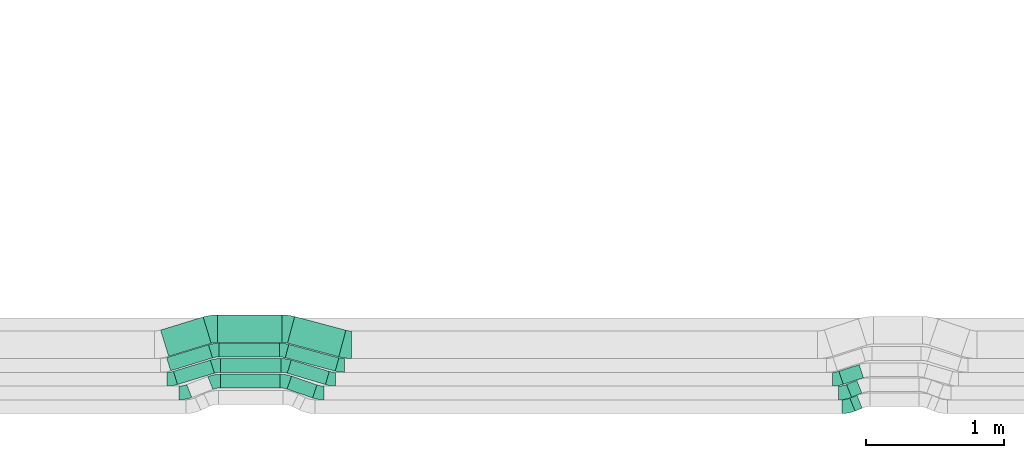
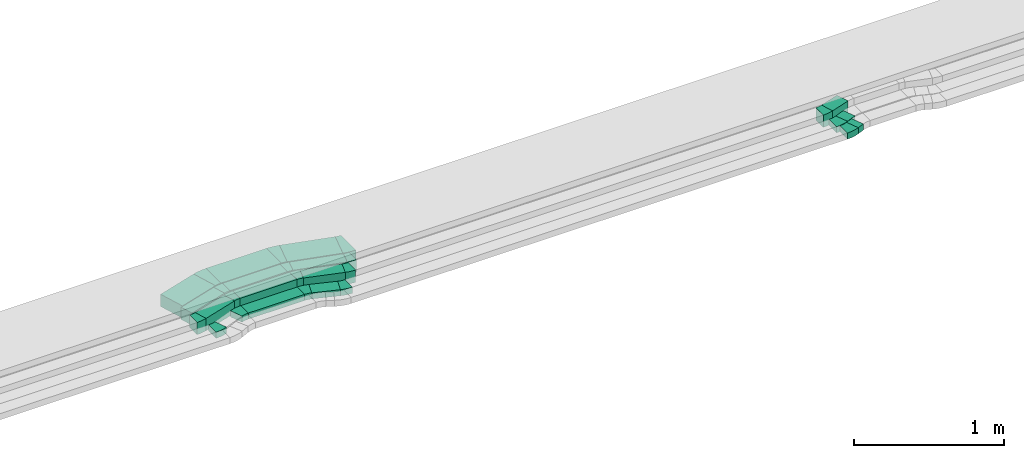
# One storey, part 19 of 38: 17 flow fittings, 14 flow segments.
"""IFC2X3 building model written with IfcOpenShell, lengths in millimetres."""

from ifc_helpers import new_model, entity, si_unit, converted_unit, derived_unit, direction, frame, frame_2d, origin, origin_2d_with_axis, place, context, subcontext, project, spatial, polyline, circle_curve, parameter, trimmed, segment, composite_curve, rectangle, outline, extrude, source, transform, mapped, material, type_object, type_shapes, element, save


model = new_model("IFC2X3")

# Units and contexts
model_context = context("Model", 3, precision=0.01, world=origin(), true_north=direction((6.12303176911189e-17, 1.0)))
body_context = subcontext(model_context, "Body", "Model", "MODEL_VIEW")
ifc_project = project(units=[si_unit("LENGTHUNIT", "METRE", prefix="MILLI"), si_unit("AREAUNIT", "SQUARE_METRE"), si_unit("VOLUMEUNIT", "CUBIC_METRE"), converted_unit("PLANEANGLEUNIT", "DEGREE", entity("IfcRatioMeasure", 0.0174532925199433), si_unit("PLANEANGLEUNIT", "RADIAN"), dimensions=[0, 0, 0, 0, 0, 0, 0]), si_unit("MASSUNIT", "GRAM", prefix="KILO"), derived_unit("MASSDENSITYUNIT", [(si_unit("MASSUNIT", "GRAM", prefix="KILO"), 1), (si_unit("LENGTHUNIT", "METRE"), -3)]), derived_unit("MOMENTOFINERTIAUNIT", [(si_unit("LENGTHUNIT", "METRE"), 4)]), si_unit("TIMEUNIT", "SECOND"), si_unit("FREQUENCYUNIT", "HERTZ"), si_unit("THERMODYNAMICTEMPERATUREUNIT", "DEGREE_CELSIUS"), derived_unit("THERMALTRANSMITTANCEUNIT", [(si_unit("MASSUNIT", "GRAM", prefix="KILO"), 1), (si_unit("THERMODYNAMICTEMPERATUREUNIT", "KELVIN"), -1), (si_unit("TIMEUNIT", "SECOND"), -3)]), derived_unit("VOLUMETRICFLOWRATEUNIT", [(si_unit("LENGTHUNIT", "METRE"), 3), (si_unit("TIMEUNIT", "SECOND"), -1)]), derived_unit("MASSFLOWRATEUNIT", [(si_unit("MASSUNIT", "GRAM", prefix="KILO"), 1), (si_unit("TIMEUNIT", "SECOND"), -1)]), derived_unit("ROTATIONALFREQUENCYUNIT", [(si_unit("TIMEUNIT", "SECOND"), -1)]), si_unit("ELECTRICCURRENTUNIT", "AMPERE"), si_unit("ELECTRICVOLTAGEUNIT", "VOLT"), si_unit("POWERUNIT", "WATT"), si_unit("FORCEUNIT", "NEWTON", prefix="KILO"), si_unit("ILLUMINANCEUNIT", "LUX"), si_unit("LUMINOUSFLUXUNIT", "LUMEN"), si_unit("LUMINOUSINTENSITYUNIT", "CANDELA"), derived_unit("USERDEFINED", [(si_unit("MASSUNIT", "GRAM", prefix="KILO"), -1), (si_unit("LENGTHUNIT", "METRE"), -2), (si_unit("TIMEUNIT", "SECOND"), 3), (si_unit("LUMINOUSFLUXUNIT", "LUMEN"), 1)]), derived_unit("LINEARVELOCITYUNIT", [(si_unit("LENGTHUNIT", "METRE"), 1), (si_unit("TIMEUNIT", "SECOND"), -1)]), si_unit("PRESSUREUNIT", "PASCAL"), derived_unit("USERDEFINED", [(si_unit("LENGTHUNIT", "METRE"), -2), (si_unit("MASSUNIT", "GRAM", prefix="KILO"), 1), (si_unit("TIMEUNIT", "SECOND"), -2)]), derived_unit("LINEARFORCEUNIT", [(si_unit("MASSUNIT", "GRAM", prefix="KILO"), 1), (si_unit("LENGTHUNIT", "METRE"), 1), (si_unit("TIMEUNIT", "SECOND"), -2), (si_unit("LENGTHUNIT", "METRE"), -1)]), derived_unit("PLANARFORCEUNIT", [(si_unit("MASSUNIT", "GRAM", prefix="KILO"), 1), (si_unit("LENGTHUNIT", "METRE"), 1), (si_unit("TIMEUNIT", "SECOND"), -2), (si_unit("LENGTHUNIT", "METRE"), -2)])], contexts=[model_context])

# Site, building, storey
site_placement = place(None, frame((0.0, -0.00077364408347762, 0.0)))
site = spatial("IfcSite", under=ifc_project, at=site_placement, CompositionType="ELEMENT")
building_placement = place(site_placement, origin())
building = spatial("IfcBuilding", under=site, at=building_placement, CompositionType="ELEMENT")
storey_placement = place(building_placement, frame((0.0, 0.0, 4200.0)))
storey = spatial("IfcBuildingStorey", under=building, at=storey_placement, CompositionType="ELEMENT", Elevation=4200.0)

# Flow segments
cable_carrier_segment_type = type_object("IfcCableCarrierSegmentType", PredefinedType="CABLETRAYSEGMENT")
flow_segment_1_placement = place(storey_placement, frame((26055.235208137, 360.54373697559, 2836.0)))
element("IfcFlowSegment", 1, at=flow_segment_1_placement, inside=storey, type_object=cable_carrier_segment_type, context=body_context, shape_type="SweptSolid", body=[
    extrude(rectangle(XDim=195.943347391639, YDim=100.0, at=frame_2d((-2.06057393370429e-12, -7.069900220813e-13), x_axis=(1.0, 0.0))), frame((108.901349712425, 79.1174192417576, 0.0), z_axis=(0.0, 0.0, 1.0), x_axis=(-0.945752611859261, 0.324887668527733, 0.0)), (0.0, 0.0, 1.0), 49.9999999999995),
])
flow_segment_2_placement = place(storey_placement, frame((25571.8881138953, 432.665310162791, 2836.0)))
element("IfcFlowSegment", 2, at=flow_segment_2_placement, inside=storey, type_object=cable_carrier_segment_type, context=body_context, shape_type="SweptSolid", body=[
    extrude(rectangle(XDim=432.668191350646, YDim=100.0, at=frame_2d((2.1600499167107e-12, 3.19744231092045e-14), x_axis=(1.0, 0.0))), frame((216.334095675321, 50.0, 0.0)), (0.0, 0.0, 1.0), 49.9999999999995),
])
flow_segment_3_placement = place(storey_placement, frame((25230.2802992273, 457.87318498589, 2836.0)))
element("IfcFlowSegment", 3, at=flow_segment_3_placement, inside=storey, type_object=cable_carrier_segment_type, context=body_context, shape_type="SweptSolid", body=[
    extrude(rectangle(XDim=280.249961443924, YDim=99.9999999999995, at=frame_2d((1.4210854715202e-14, 3.19744231092045e-14), x_axis=(1.0, 0.0))), frame((148.620770729778, 88.783817286081, 0.0), z_axis=(0.0, 0.0, 1.0), x_axis=(0.956304755963014, 0.292371704722806, 0.0)), (0.0, 0.0, 1.0), 100.000000000001),
])
flow_segment_4_placement = place(storey_placement, frame((25573.3339011512, 546.657002272017, 2836.0)))
element("IfcFlowSegment", 4, at=flow_segment_4_placement, inside=storey, type_object=cable_carrier_segment_type, context=body_context, shape_type="SweptSolid", body=[
    extrude(rectangle(XDim=438.862057523162, YDim=100.0, at=frame_2d((0.0, -3.5527136788005e-14), x_axis=(1.0, 0.0))), frame((219.431028761581, 50.0, 0.0)), (0.0, 0.0, 1.0), 100.000000000001),
])
flow_segment_5_placement = place(storey_placement, frame((26057.1071127944, 457.412348731987, 2836.0)))
element("IfcFlowSegment", 5, at=flow_segment_5_placement, inside=storey, type_object=cable_carrier_segment_type, context=body_context, shape_type="SweptSolid", body=[
    extrude(rectangle(XDim=288.72318462941, YDim=99.9999999999977, at=origin_2d_with_axis()), frame((152.633987056966, 89.2446535399927, 0.0), z_axis=(0.0, 0.0, 1.0), x_axis=(-0.958124028295565, 0.286353533944806, 0.0)), (0.0, 0.0, 1.0), 100.000000000001),
])
flow_segment_6_placement = place(storey_placement, frame((25180.3949491212, 557.873184985964, 2836.0)))
element("IfcFlowSegment", 6, at=flow_segment_6_placement, inside=storey, type_object=cable_carrier_segment_type, context=body_context, shape_type="SweptSolid", body=[
    extrude(rectangle(XDim=318.219599460334, YDim=100.000000000001, at=frame_2d((-2.1032064978499e-12, 5.6843418860808e-13), x_axis=(1.0, 0.0))), frame((166.776043438429, 94.3344411833753, 0.0), z_axis=(0.0, 0.0, 1.0), x_axis=(0.956304755962991, 0.292371704722884, 0.0)), (0.0, 0.0, 1.0), 100.000000000001),
])
flow_segment_7_placement = place(storey_placement, frame((25559.7590964624, 657.75825006668, 2836.0)))
element("IfcFlowSegment", 7, at=flow_segment_7_placement, inside=storey, type_object=cable_carrier_segment_type, context=body_context, shape_type="SweptSolid", body=[
    extrude(rectangle(XDim=441.841589698417, YDim=100.0, at=frame_2d((-2.1600499167107e-12, 0.0), x_axis=(1.0, 0.0))), frame((220.920794849211, 50.0, 0.0)), (0.0, 0.0, 1.0), 100.000000000001),
])
flow_segment_8_placement = place(storey_placement, frame((26042.3009032749, 555.394199332218, 2836.0)))
element("IfcFlowSegment", 8, at=flow_segment_8_placement, inside=storey, type_object=cable_carrier_segment_type, context=body_context, shape_type="SweptSolid", body=[
    extrude(rectangle(XDim=375.709099375741, YDim=100.000000000002, at=origin_2d_with_axis()), frame((194.394675357713, 96.8134268371303, 0.0), z_axis=(0.0, 0.0, 1.0), x_axis=(0.966084121972167, -0.258227553280565, 0.0)), (0.0, 0.0, 1.0), 100.000000000001),
])
flow_segment_9_placement = place(storey_placement, frame((25136.7840466044, 662.24270938973, 2836.0)))
element("IfcFlowSegment", 9, at=flow_segment_9_placement, inside=storey, type_object=cable_carrier_segment_type, context=body_context, shape_type="SweptSolid", body=[
    extrude(rectangle(XDim=323.274499325405, YDim=199.999999999997, at=frame_2d((2.04636307898909e-12, -6.96331881044898e-13), x_axis=(1.0, 0.0))), frame((183.811641065499, 142.888633826899, 0.0), z_axis=(0.0, 0.0, 1.0), x_axis=(0.956304755962995, 0.292371704722868, 0.0)), (0.0, 0.0, 1.0), 100.000000000001),
])
flow_segment_10_placement = place(storey_placement, frame((25550.2193891998, 763.605684161198, 2836.0)))
element("IfcFlowSegment", 10, at=flow_segment_10_placement, inside=storey, type_object=cable_carrier_segment_type, context=body_context, shape_type="SweptSolid", body=[
    extrude(rectangle(XDim=467.801987122986, YDim=200.0, at=frame_2d((-2.1600499167107e-12, -6.3948846218409e-14), x_axis=(1.0, 0.0))), frame((233.900993561491, 100.0, 0.0)), (0.0, 0.0, 1.0), 100.000000000001),
])
flow_segment_11_placement = place(storey_placement, frame((26058.7215934368, 658.785787135088, 2836.0)))
element("IfcFlowSegment", 11, at=flow_segment_11_placement, inside=storey, type_object=cable_carrier_segment_type, context=body_context, shape_type="SweptSolid", body=[
    extrude(rectangle(XDim=385.219495382676, YDim=199.999999999999, at=frame_2d((-2.06057393370429e-12, -6.18172180111287e-13), x_axis=(1.0, 0.0))), frame((211.899974309726, 146.345556081543, 0.0), z_axis=(0.0, 0.0, 1.0), x_axis=(0.966084121972157, -0.258227553280602, 0.0)), (0.0, 0.0, 1.0), 100.000000000001),
])
flow_segment_12_placement = place(storey_placement, frame((30142.5643710702, 265.235645223721, 2836.0)))
element("IfcFlowSegment", 12, at=flow_segment_12_placement, inside=storey, type_object=cable_carrier_segment_type, context=body_context, shape_type="SweptSolid", body=[
    extrude(rectangle(XDim=55.2478763448979, YDim=99.9999999999959, at=frame_2d((2.02682315375569e-12, -7.56728013584507e-13), x_axis=(1.0, 0.0))), frame((44.3427991438512, 56.7073021038535, 0.0), z_axis=(0.0, 0.0, 1.0), x_axis=(0.927183854566641, 0.374606593416275, 0.0)), (0.0, 0.0, 1.0), 49.9999999999994),
])
flow_segment_13_placement = place(storey_placement, frame((30117.5643710702, 365.235645223648, 2836.0)))
element("IfcFlowSegment", 13, at=flow_segment_13_placement, inside=storey, type_object=cable_carrier_segment_type, context=body_context, shape_type="SweptSolid", body=[
    extrude(rectangle(XDim=80.2478763448968, YDim=100.000000000003, at=frame_2d((1.99662508748588e-12, -8.41993141875719e-13), x_axis=(1.0, 0.0))), frame((55.9325973259627, 61.3898845215714, 0.0), z_axis=(0.0, 0.0, 1.0), x_axis=(0.92718385456639, 0.374606593416895, 0.0)), (0.0, 0.0, 1.0), 49.9999999999994),
])
flow_segment_14_placement = place(storey_placement, frame((30062.665216429, 459.201890192554, 2836.0)))
element("IfcFlowSegment", 14, at=flow_segment_14_placement, inside=storey, type_object=cable_carrier_segment_type, context=body_context, shape_type="SweptSolid", body=[
    extrude(rectangle(XDim=154.646223870172, YDim=100.000000000002, at=frame_2d((2.08189021577709e-12, -6.00408611717285e-13), x_axis=(1.0, 0.0))), frame((88.989499184833, 71.4469814606642, 0.0), z_axis=(0.0, 0.0, 1.0), x_axis=(0.951056516295111, 0.309016994375079, 0.0)), (0.0, 0.0, 1.0), 99.9999999999989),
])

# Flow fittings
ifc_material = material()
cable_carrier_fitting_type_1 = type_object("IfcCableCarrierFittingType", Name="470_DKC_S5_Variable Angle Elbow 0-45:-", PredefinedType="NOTDEFINED", material=ifc_material)
shared_shape_1 = source(origin(), body_context, "Body", "SweptSolid", [
    extrude(outline(composite_curve([segment(polyline([(-38.442455305234, -57.3752661916753), (-37.4424553052327, -57.3752661916753)]), True, "CONTINUOUS"), segment(trimmed(circle_curve(frame_2d((-37.4424553052331, 192.624733808324), x_axis=(0.0, -1.0)), 250.0), [parameter(0.0)], [parameter(22.0)], True, "PARAMETER"), True, "CONTINUOUS"), segment(polyline([(56.2091930487454, -39.1712298333719), (57.1363769033121, -38.7966232399561)]), True, "CONTINUOUS"), segment(polyline([(57.1363769033121, -38.7966232399561), (19.6757175617208, 53.9217622167225)]), True, "CONTINUOUS"), segment(polyline([(19.6757175617208, 53.9217622167225), (18.748533707154, 53.5471556233066)]), True, "CONTINUOUS"), segment(trimmed(circle_curve(frame_2d((-37.4424553052331, 192.624733808324), x_axis=(0.0, -1.0)), 150.0), [parameter(0.0)], [parameter(22.0)], True, "PARAMETER"), False, "CONTINUOUS"), segment(polyline([(-37.4424553052327, 42.6247338083246), (-38.442455305234, 42.6247338083246)]), True, "CONTINUOUS"), segment(polyline([(-38.442455305234, 42.6247338083246), (-38.442455305234, -57.3752661916753)]), True, "CONTINUOUS")], self_intersect=False)), frame((-1.43360652230106, 7.37526619166724, -25.0)), (0.0, 0.0, 1.0), 50.0000000000001),
])
type_shapes(cable_carrier_fitting_type_1, [shared_shape_1])
for number, where, name in (
    (15, (30124.3222600308, 296.657002272009, 2861.0), "470_DKC_S5_Variable Angle Elbow 0-45:-"),
    (16, (30099.3222600308, 396.657002271926, 2861.0), "470_DKC_S5_Variable Angle Elbow 0-45:-"),
):
    element("IfcFlowFitting", number, at=place(storey_placement, frame(where)), inside=storey, type_object=cable_carrier_fitting_type_1, material=ifc_material, Name=name, ObjectType="470_DKC_S5_Variable Angle Elbow 0-45:-", context=body_context, shape_type="MappedRepresentation", body=[
        mapped(shared_shape_1, transform((0.0, 0.0, 0.0), scale=1.0)),
    ])
cable_carrier_fitting_type_2 = type_object("IfcCableCarrierFittingType", Name="470_DKC_S5_Variable Angle Elbow 0-45:-", PredefinedType="NOTDEFINED", material=ifc_material)
shared_shape_2 = source(origin(), body_context, "Body", "SweptSolid", [
    extrude(outline(composite_curve([segment(polyline([(-36.8201900611553, -56.7315493376662), (-35.820190061154, -56.7315493376662)]), True, "CONTINUOUS"), segment(trimmed(circle_curve(frame_2d((-35.8201900611544, 193.268450662333), x_axis=(0.0, -1.0)), 250.0), [parameter(0.0)], [parameter(21.0)], True, "PARAMETER"), True, "CONTINUOUS"), segment(polyline([(53.7717973251708, -40.1266559619665), (54.7053777516679, -39.7682880124213)]), True, "CONTINUOUS"), segment(polyline([(54.7053777516679, -39.7682880124213), (18.868582797138, 53.5897546372988)]), True, "CONTINUOUS"), segment(polyline([(18.868582797138, 53.5897546372988), (17.9350023706407, 53.2313866877535)]), True, "CONTINUOUS"), segment(trimmed(circle_curve(frame_2d((-35.8201900611544, 193.268450662333), x_axis=(0.0, -1.0)), 150.0), [parameter(0.0)], [parameter(21.0)], True, "PARAMETER"), False, "CONTINUOUS"), segment(polyline([(-35.820190061154, 43.2684506623337), (-36.8201900611553, 43.2684506623337)]), True, "CONTINUOUS"), segment(polyline([(-36.8201900611553, 43.2684506623337), (-36.8201900611553, -56.7315493376662)]), True, "CONTINUOUS")], self_intersect=False)), frame((-1.24761892514277, 6.7315493376581, -25.0)), (0.0, 0.0, 1.0), 50.0000000000001),
])
type_shapes(cable_carrier_fitting_type_2, [shared_shape_2])
flow_fitting_1_placement = place(storey_placement, frame((25309.7610025497, 396.657002271919, 2861.0)))
element("IfcFlowFitting", 17, at=flow_fitting_1_placement, inside=storey, type_object=cable_carrier_fitting_type_2, material=ifc_material, Name="470_DKC_S5_Variable Angle Elbow 0-45:-", ObjectType="470_DKC_S5_Variable Angle Elbow 0-45:-", context=body_context, shape_type="MappedRepresentation", body=[
    mapped(shared_shape_2, transform((0.0, 0.0, 0.0), scale=1.0)),
])
flow_fitting_2_placement = place(storey_placement, frame((25533.820304909, 482.665310162774, 2861.0), z_axis=(0.0, 0.0, 1.0), x_axis=(-1.0, 0.0, 0.0)))
element("IfcFlowFitting", 18, at=flow_fitting_2_placement, inside=storey, type_object=cable_carrier_fitting_type_2, material=ifc_material, Name="470_DKC_S5_Variable Angle Elbow 0-45:-", ObjectType="470_DKC_S5_Variable Angle Elbow 0-45:-", context=body_context, shape_type="MappedRepresentation", body=[
    mapped(shared_shape_2, transform((0.0, 0.0, 0.0), scale=1.0)),
])
cable_carrier_fitting_type_3 = type_object("IfcCableCarrierFittingType", Name="470_DKC_S5_Variable Angle Elbow 0-45:-", PredefinedType="NOTDEFINED", material=ifc_material)
shared_shape_3 = source(origin(), body_context, "Body", "SweptSolid", [
    extrude(outline(composite_curve([segment(polyline([(-33.4752050057318, -55.5059607312033), (-32.4752050057305, -55.5059607312033)]), True, "CONTINUOUS"), segment(trimmed(circle_curve(frame_2d((-32.4752050057309, 194.494039268796), x_axis=(0.0, -1.0)), 250.0), [parameter(0.0)], [parameter(18.9587695616004)], True, "PARAMETER"), True, "CONTINUOUS"), segment(polyline([(48.7467121261843, -41.9441136960248), (49.6924647380436, -41.6192260274971)]), True, "CONTINUOUS"), segment(polyline([(49.6924647380436, -41.619226027497), (17.2036978852775, 52.9560351584314)]), True, "CONTINUOUS"), segment(polyline([(17.2036978852775, 52.9560351584314), (16.2579452734182, 52.6311474899037)]), True, "CONTINUOUS"), segment(trimmed(circle_curve(frame_2d((-32.4752050057309, 194.494039268796), x_axis=(0.0, -1.0)), 150.0), [parameter(0.0)], [parameter(18.9587695616004)], True, "PARAMETER"), False, "CONTINUOUS"), segment(polyline([(-32.4752050057305, 44.4940392687965), (-33.4752050057318, 44.4940392687965)]), True, "CONTINUOUS"), segment(polyline([(-33.4752050057318, 44.4940392687965), (-33.4752050057318, -55.5059607312033)]), True, "CONTINUOUS")], self_intersect=False)), frame((-0.919345416289682, 5.50596073119527, -25.0)), (0.0, 0.0, 1.0), 50.0000000000001),
])
type_shapes(cable_carrier_fitting_type_3, [shared_shape_3])
for number, where, z_axis, x_axis, name in (
    (19, (26289.3222600308, 396.657002271904, 2861.0), (0.0, 0.0, 1.0), (0.945752611859286, -0.324887668527659, 0.0), "470_DKC_S5_Variable Angle Elbow 0-45:-"),
    (20, (26038.950855668, 482.665310162805, 2861.0), (0.0, 0.0, 1.0), (-0.945752611859261, 0.324887668527733, 0.0), "470_DKC_S5_Variable Angle Elbow 0-45:-"),
):
    element("IfcFlowFitting", number, at=place(storey_placement, frame(where, z_axis=z_axis, x_axis=x_axis)), inside=storey, type_object=cable_carrier_fitting_type_3, material=ifc_material, Name=name, ObjectType="470_DKC_S5_Variable Angle Elbow 0-45:-", context=body_context, shape_type="MappedRepresentation", body=[
        mapped(shared_shape_3, transform((0.0, 0.0, 0.0), scale=1.0)),
    ])
cable_carrier_fitting_type_4 = type_object("IfcCableCarrierFittingType", Name="470_DKC_S5_Variable Angle Elbow 0-45:-", PredefinedType="NOTDEFINED", material=ifc_material)
shared_shape_4 = source(origin(), body_context, "Body", "SweptSolid", [
    extrude(outline(composite_curve([segment(polyline([(-30.226246661265, -54.4426173298774), (-29.2262466612637, -54.4426173298774)]), True, "CONTINUOUS"), segment(trimmed(circle_curve(frame_2d((-29.2262466612662, 195.557382670122), x_axis=(0.0, -1.0)), 250.0), [parameter(0.0)], [parameter(17.0)], True, "PARAMETER"), True, "CONTINUOUS"), segment(polyline([(43.8666795194203, -43.5188063206355), (44.8229842753832, -43.2264346159128)]), True, "CONTINUOUS"), segment(polyline([(44.8229842753832, -43.2264346159128), (15.5858138031087, 52.4040409803904)]), True, "CONTINUOUS"), segment(polyline([(15.5858138031087, 52.4040409803904), (14.6295090471456, 52.1116692756676)]), True, "CONTINUOUS"), segment(trimmed(circle_curve(frame_2d((-29.2262466612662, 195.557382670122), x_axis=(0.0, -1.0)), 150.0), [parameter(0.0)], [parameter(17.0)], True, "PARAMETER"), False, "CONTINUOUS"), segment(polyline([(-29.2262466612645, 45.5573826701225), (-30.2262466612658, 45.5573826701225)]), True, "CONTINUOUS"), segment(polyline([(-30.2262466612658, 45.5573826701225), (-30.226246661265, -54.4426173298774)]), True, "CONTINUOUS")], self_intersect=False)), frame((-0.663953608551355, 4.44261732986909, -50.0)), (0.0, 0.0, 1.0), 100.0),
])
type_shapes(cable_carrier_fitting_type_4, [shared_shape_4])
flow_fitting_3_placement = place(storey_placement, frame((25215.3584390328, 496.657002271942, 2886.0)))
element("IfcFlowFitting", 21, at=flow_fitting_3_placement, inside=storey, type_object=cable_carrier_fitting_type_4, material=ifc_material, Name="470_DKC_S5_Variable Angle Elbow 0-45:-", ObjectType="470_DKC_S5_Variable Angle Elbow 0-45:-", context=body_context, shape_type="MappedRepresentation", body=[
    mapped(shared_shape_4, transform((0.0, 0.0, 0.0), scale=1.0)),
])
for number, where, z_axis, x_axis, name in (
    (22, (25542.4437008814, 596.657002272, 2886.0), (0.0, 0.0, 1.0), (-1.0, 0.0, 0.0), "470_DKC_S5_Variable Angle Elbow 0-45:-"),
    (23, (25528.8688961926, 707.758250066664, 2886.0), (0.0, 0.0, 1.0), (-1.0, 0.0, 0.0), "470_DKC_S5_Variable Angle Elbow 0-45:-"),
):
    element("IfcFlowFitting", number, at=place(storey_placement, frame(where, z_axis=z_axis, x_axis=x_axis)), inside=storey, type_object=cable_carrier_fitting_type_4, material=ifc_material, Name=name, ObjectType="470_DKC_S5_Variable Angle Elbow 0-45:-", context=body_context, shape_type="MappedRepresentation", body=[
        mapped(shared_shape_4, transform((0.0, 0.0, 0.0), scale=1.0)),
    ])
cable_carrier_fitting_type_5 = type_object("IfcCableCarrierFittingType", Name="470_DKC_S5_Variable Angle Elbow 0-45:-", PredefinedType="NOTDEFINED", material=ifc_material)
shared_shape_5 = source(origin(), body_context, "Body", "SweptSolid", [
    extrude(outline(composite_curve([segment(polyline([(-29.6248844015493, -54.2591855539282), (-28.624884401548, -54.2591855539282)]), True, "CONTINUOUS"), segment(trimmed(circle_curve(frame_2d((-28.6248844015505, 195.740814446071), x_axis=(0.0, -1.0)), 250.0), [parameter(0.0)], [parameter(16.6397728105934)], True, "PARAMETER"), True, "CONTINUOUS"), segment(polyline([(42.9634990846389, -43.7901926278231), (43.9216231129343, -43.5038390938784)]), True, "CONTINUOUS"), segment(polyline([(43.9216231129343, -43.5038390938784), (15.2862697184588, 52.3085637356796)]), True, "CONTINUOUS"), segment(polyline([(15.2862697184588, 52.3085637356796), (14.3281456901631, 52.0222102017348)]), True, "CONTINUOUS"), segment(trimmed(circle_curve(frame_2d((-28.6248844015505, 195.740814446071), x_axis=(0.0, -1.0)), 150.0), [parameter(0.0)], [parameter(16.6397728105934)], True, "PARAMETER"), False, "CONTINUOUS"), segment(polyline([(-28.6248844015488, 45.7408144460717), (-29.6248844015501, 45.7408144460717)]), True, "CONTINUOUS"), segment(polyline([(-29.6248844015501, 45.7408144460717), (-29.6248844015493, -54.2591855539282)]), True, "CONTINUOUS")], self_intersect=False)), frame((-0.622857805455855, 4.25918555391992, -50.0)), (0.0, 0.0, 1.0), 100.0),
])
type_shapes(cable_carrier_fitting_type_5, [shared_shape_5])
for number, where, z_axis, x_axis, name in (
    (24, (26377.0384988213, 496.657002271956, 2886.0), (0.0, 0.0, 1.0), (0.958124028295574, -0.286353533944775, 0.0), "470_DKC_S5_Variable Angle Elbow 0-45:-"),
    (25, (26042.4437008814, 596.657002272013, 2886.0), (0.0, 0.0, 1.0), (-0.958124028295565, 0.286353533944807, 0.0), "470_DKC_S5_Variable Angle Elbow 0-45:-"),
):
    element("IfcFlowFitting", number, at=place(storey_placement, frame(where, z_axis=z_axis, x_axis=x_axis)), inside=storey, type_object=cable_carrier_fitting_type_5, material=ifc_material, Name=name, ObjectType="470_DKC_S5_Variable Angle Elbow 0-45:-", context=body_context, shape_type="MappedRepresentation", body=[
        mapped(shared_shape_5, transform((0.0, 0.0, 0.0), scale=1.0)),
    ])
cable_carrier_fitting_type_6 = type_object("IfcCableCarrierFittingType", Name="470_DKC_S5_Variable Angle Elbow 0-45:-", PredefinedType="NOTDEFINED", material=ifc_material)
shared_shape_6 = source(origin(), body_context, "Body", "SweptSolid", [
    extrude(outline(composite_curve([segment(polyline([(-26.8142763585466, -53.4561446911027), (-25.8142763585453, -53.4561446911027)]), True, "CONTINUOUS"), segment(trimmed(circle_curve(frame_2d((-25.8142763585479, 196.543855308897), x_axis=(0.0, -1.0)), 250.0), [parameter(0.0)], [parameter(14.9649173815194)], True, "PARAMETER"), True, "CONTINUOUS"), segment(polyline([(38.742611961587, -44.9771751841462), (39.7086960835591, -44.7189476308657)]), True, "CONTINUOUS"), segment(polyline([(39.7086960835591, -44.7189476308657), (13.8859407555053, 51.8894645663516)]), True, "CONTINUOUS"), segment(polyline([(13.8859407555053, 51.8894645663516), (12.919856633533, 51.6312370130711)]), True, "CONTINUOUS"), segment(trimmed(circle_curve(frame_2d((-25.8142763585479, 196.543855308897), x_axis=(0.0, -1.0)), 150.0), [parameter(0.0)], [parameter(14.9649173815194)], True, "PARAMETER"), False, "CONTINUOUS"), segment(polyline([(-25.8142763585461, 46.5438553088972), (-26.8142763585474, 46.5438553088972)]), True, "CONTINUOUS"), segment(polyline([(-26.8142763585474, 46.5438553088972), (-26.8142763585466, -53.4561446911027)]), True, "CONTINUOUS")], self_intersect=False)), frame((-0.453933673220663, 3.45614469109444, -50.0)), (0.0, 0.0, 1.0), 100.0),
])
type_shapes(cable_carrier_fitting_type_6, [shared_shape_6])
for number, where, z_axis, x_axis, name in (
    (26, (26028.8688961926, 707.758250066696, 2886.0), (0.0, 0.0, 1.0), (-0.966084121972172, 0.258227553280546, 0.0), "470_DKC_S5_Variable Angle Elbow 0-45:-"),
    (27, (26444.5222610726, 596.657002271992, 2886.0), (0.0, 0.0, 1.0), (0.966084121972167, -0.258227553280564, 0.0), "470_DKC_S5_Variable Angle Elbow 0-45:-"),
):
    element("IfcFlowFitting", number, at=place(storey_placement, frame(where, z_axis=z_axis, x_axis=x_axis)), inside=storey, type_object=cable_carrier_fitting_type_6, material=ifc_material, Name=name, ObjectType="470_DKC_S5_Variable Angle Elbow 0-45:-", context=body_context, shape_type="MappedRepresentation", body=[
        mapped(shared_shape_6, transform((0.0, 0.0, 0.0), scale=1.0)),
    ])
cable_carrier_fitting_type_7 = type_object("IfcCableCarrierFittingType", Name="470_DKC_S5_Variable Angle Elbow 0-45:-", PredefinedType="NOTDEFINED", material=ifc_material)
shared_shape_7 = source(origin(), body_context, "Body", "SweptSolid", [
    extrude(outline(composite_curve([segment(polyline([(-37.5355392793425, -105.534998430804), (-36.5355392793411, -105.534998430804)]), True, "CONTINUOUS"), segment(trimmed(circle_curve(frame_2d((-36.5355392793416, 244.465001569196), x_axis=(0.0, -1.0)), 350.0), [parameter(0.0)], [parameter(17.0000000000041)], True, "PARAMETER"), True, "CONTINUOUS"), segment(polyline([(65.7945573736406, -90.2416630178589), (66.7508621296033, -89.9492913131361)]), True, "CONTINUOUS"), segment(polyline([(66.7508621296034, -89.9492913131362), (8.27652118504255, 101.311659879467)]), True, "CONTINUOUS"), segment(polyline([(8.27652118504254, 101.311659879467), (7.32021642907929, 101.019288174744)]), True, "CONTINUOUS"), segment(trimmed(circle_curve(frame_2d((-36.5355392793416, 244.465001569196), x_axis=(0.0, -1.0)), 150.0), [parameter(0.0)], [parameter(17.0000000000041)], True, "PARAMETER"), False, "CONTINUOUS"), segment(polyline([(-36.5355392793411, 94.465001569196), (-37.5355392793425, 94.465001569196)]), True, "CONTINUOUS"), segment(polyline([(-37.5355392793425, 94.465001569196), (-37.5355392793425, -105.534998430804)]), True, "CONTINUOUS")], self_intersect=False)), frame((-0.827211057939807, 5.53499843079583, -50.0)), (0.0, 0.0, 1.0), 100.0),
])
type_shapes(cable_carrier_fitting_type_7, [shared_shape_7])
flow_fitting_4_placement = place(storey_placement, frame((25511.8566388625, 863.605684161182, 2886.0), z_axis=(0.0, 0.0, 1.0), x_axis=(-1.0, 0.0, 0.0)))
element("IfcFlowFitting", 28, at=flow_fitting_4_placement, inside=storey, type_object=cable_carrier_fitting_type_7, material=ifc_material, Name="470_DKC_S5_Variable Angle Elbow 0-45:-", ObjectType="470_DKC_S5_Variable Angle Elbow 0-45:-", context=body_context, shape_type="MappedRepresentation", body=[
    mapped(shared_shape_7, transform((0.0, 0.0, 0.0), scale=1.0)),
])
cable_carrier_fitting_type_8 = type_object("IfcCableCarrierFittingType", Name="470_DKC_S5_Variable Angle Elbow 0-45:-", PredefinedType="NOTDEFINED", material=ifc_material)
shared_shape_8 = source(origin(), body_context, "Body", "SweptSolid", [
    extrude(outline(composite_curve([segment(polyline([(-33.269965190565, -104.304041641799), (-32.2699651905636, -104.304041641799)]), True, "CONTINUOUS"), segment(trimmed(circle_curve(frame_2d((-32.2699651905642, 245.6959583582), x_axis=(0.0, -1.0)), 350.0), [parameter(0.0)], [parameter(14.9649173815217)], True, "PARAMETER"), True, "CONTINUOUS"), segment(polyline([(58.1096784576348, -92.4334843320575), (59.0757625796066, -92.175256778777)]), True, "CONTINUOUS"), segment(polyline([(59.0757625796066, -92.1752567787771), (7.43025192349364, 101.041567615656)]), True, "CONTINUOUS"), segment(polyline([(7.43025192349364, 101.041567615656), (6.46416780152106, 100.783340062376)]), True, "CONTINUOUS"), segment(trimmed(circle_curve(frame_2d((-32.2699651905642, 245.6959583582), x_axis=(0.0, -1.0)), 150.0), [parameter(0.0)], [parameter(14.9649173815217)], True, "PARAMETER"), False, "CONTINUOUS"), segment(polyline([(-32.2699651905636, 95.6959583582005), (-33.269965190565, 95.6959583582005)]), True, "CONTINUOUS"), segment(polyline([(-33.269965190565, 95.6959583582005), (-33.269965190565, -104.304041641799)]), True, "CONTINUOUS")], self_intersect=False)), frame((-0.565297349151675, 4.30404164179128, -50.0)), (0.0, 0.0, 1.0), 100.0),
])
type_shapes(cable_carrier_fitting_type_8, [shared_shape_8])
for number, where, z_axis, x_axis, name in (
    (29, (26051.8566388625, 863.605684161179, 2886.0), (0.0, 0.0, 1.0), (-0.966084121972167, 0.258227553280567, 0.0), "470_DKC_S5_Variable Angle Elbow 0-45:-"),
    (30, (26489.3864966306, 746.657002272072, 2886.0), (0.0, 0.0, 1.0), (0.966084121972157, -0.258227553280602, 0.0), "470_DKC_S5_Variable Angle Elbow 0-45:-"),
):
    element("IfcFlowFitting", number, at=place(storey_placement, frame(where, z_axis=z_axis, x_axis=x_axis)), inside=storey, type_object=cable_carrier_fitting_type_8, material=ifc_material, Name=name, ObjectType="470_DKC_S5_Variable Angle Elbow 0-45:-", context=body_context, shape_type="MappedRepresentation", body=[
        mapped(shared_shape_8, transform((0.0, 0.0, 0.0), scale=1.0)),
    ])
cable_carrier_fitting_type_9 = type_object("IfcCableCarrierFittingType", Name="470_DKC_S5_Variable Angle Elbow 0-45:-", PredefinedType="NOTDEFINED", material=ifc_material)
shared_shape_9 = source(origin(), body_context, "Body", "SweptSolid", [
    extrude(outline(composite_curve([segment(polyline([(-31.8894635665691, -54.9716026190787), (-30.8894635665678, -54.9716026190787)]), True, "CONTINUOUS"), segment(trimmed(circle_curve(frame_2d((-30.8894635665704, 195.028397380921), x_axis=(0.0, -1.0)), 250.0), [parameter(0.0)], [parameter(18.0)], True, "PARAMETER"), True, "CONTINUOUS"), segment(polyline([(46.3647850271689, -42.7357316928663), (47.315841543464, -42.4267146984913)]), True, "CONTINUOUS"), segment(polyline([(47.315841543464, -42.4267146984913), (16.4141421059684, 52.6789369310236)]), True, "CONTINUOUS"), segment(polyline([(16.4141421059684, 52.6789369310236), (15.4630855896732, 52.3699199366487)]), True, "CONTINUOUS"), segment(trimmed(circle_curve(frame_2d((-30.8894635665704, 195.028397380921), x_axis=(0.0, -1.0)), 150.0), [parameter(0.0)], [parameter(18.0)], True, "PARAMETER"), False, "CONTINUOUS"), segment(polyline([(-30.8894635665686, 45.0283973809212), (-31.88946356657, 45.0283973809212)]), True, "CONTINUOUS"), segment(polyline([(-31.88946356657, 45.0283973809212), (-31.8894635665691, -54.9716026190787)]), True, "CONTINUOUS")], self_intersect=False)), frame((-0.787424498328968, 4.97160261907036, -50.0)), (0.0, 0.0, 1.0), 100.0),
])
type_shapes(cable_carrier_fitting_type_9, [shared_shape_9])
flow_fitting_5_placement = place(storey_placement, frame((30047.0384988214, 496.657002271982, 2886.0)))
element("IfcFlowFitting", 31, at=flow_fitting_5_placement, inside=storey, type_object=cable_carrier_fitting_type_9, material=ifc_material, Name="470_DKC_S5_Variable Angle Elbow 0-45:-", ObjectType="470_DKC_S5_Variable Angle Elbow 0-45:-", context=body_context, shape_type="MappedRepresentation", body=[
    mapped(shared_shape_9, transform((0.0, 0.0, 0.0), scale=1.0)),
])

save(model, "model.ifc")
